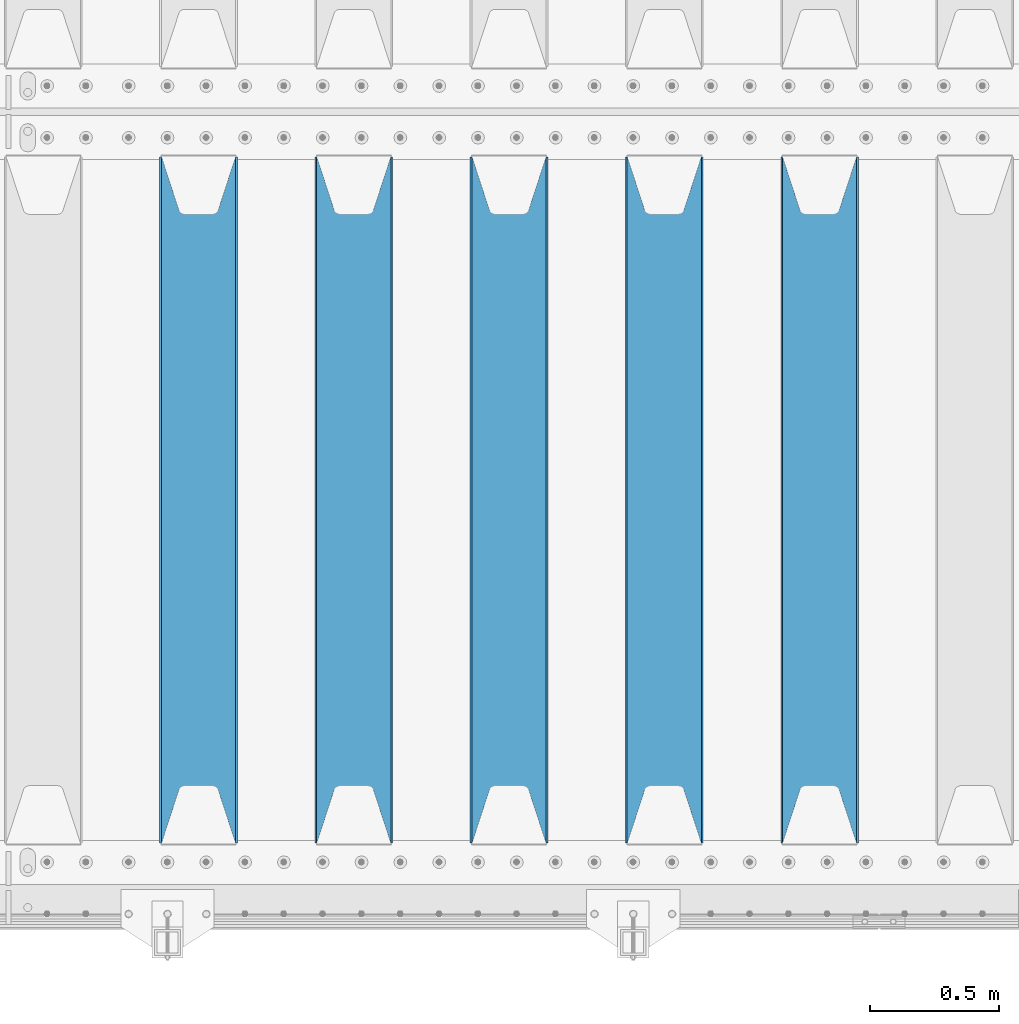
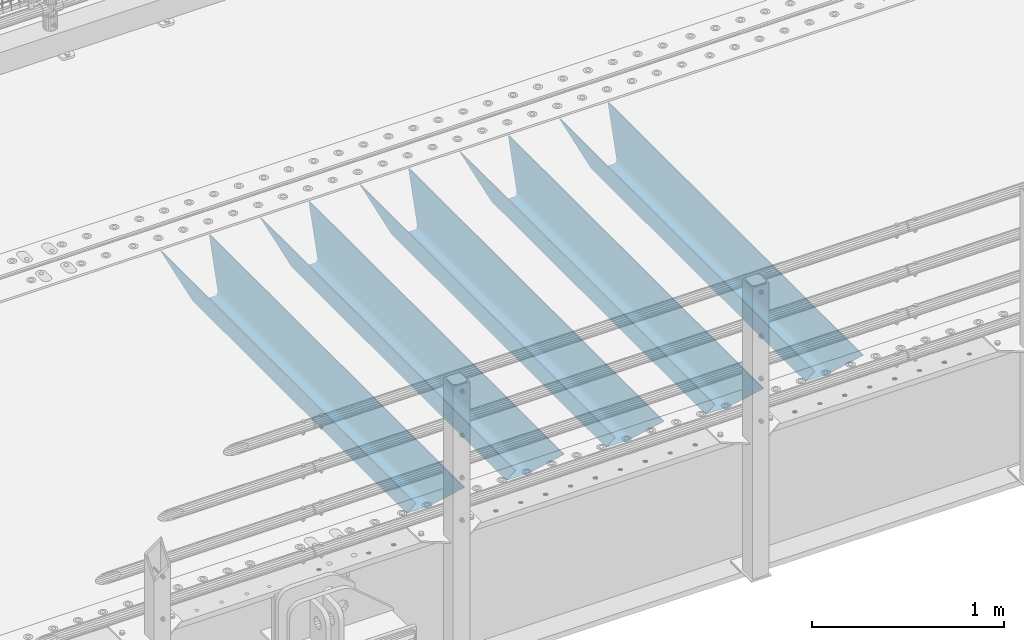
# One storey, part 129 of 242: 5 beams.
"""IFC2X3 building model written with IfcOpenShell, lengths in millimetres."""

from ifc_helpers import new_model, si_unit, frame, origin_with_axes, place, context, subcontext, project, spatial, faceted_brep, material, type_object, element, save


model = new_model("IFC2X3")

# Units and contexts
model_context = context("Model", 3, precision=1e-05, world=origin_with_axes())
body_context = subcontext(model_context, "Body", "Model", "MODEL_VIEW")
ifc_project = project(units=[si_unit("LENGTHUNIT", "METRE", prefix="MILLI"), si_unit("AREAUNIT", "SQUARE_METRE"), si_unit("VOLUMEUNIT", "CUBIC_METRE"), si_unit("MASSUNIT", "GRAM", prefix="KILO"), si_unit("TIMEUNIT", "SECOND"), si_unit("PLANEANGLEUNIT", "RADIAN"), si_unit("SOLIDANGLEUNIT", "STERADIAN"), si_unit("THERMODYNAMICTEMPERATUREUNIT", "DEGREE_CELSIUS"), si_unit("LUMINOUSINTENSITYUNIT", "LUMEN")], contexts=[model_context])

# Site, building, storey
site_placement = place(None, origin_with_axes())
site = spatial("IfcSite", under=ifc_project, at=site_placement, CompositionType="ELEMENT")
building_placement = place(site_placement, origin_with_axes())
building = spatial("IfcBuilding", under=site, at=building_placement, Name="Standard", CompositionType="ELEMENT")
storey_placement = place(building_placement, origin_with_axes())
storey = spatial("IfcBuildingStorey", under=building, at=storey_placement, Name="Undefined", CompositionType="ELEMENT", Elevation=0.0)

# Beams
ifc_material = material(Name="STEEL/S355N")
beam_type = type_object("IfcBeamType", PredefinedType="NOTDEFINED")
beam_1_placement = place(storey_placement, frame((-24980.0, -23825.0, -115.0), z_axis=(0.0, 0.0, 1.0), x_axis=(0.0, 1.0, 0.0)))
element("IfcBeam", 1, at=beam_1_placement, inside=storey, type_object=beam_type, material=ifc_material, context=body_context, shape_type="Brep", body=[
    faceted_brep([(0.0, 150.0, 115.0), (0.0, 143.689999999999, 115.0), (2650.00000000297, 143.689999999999, 115.0), (2650.00000000297, 150.0, 115.0), (2650.00000000297, 142.059565218402, 110.000000003099), (2650.00000000297, 148.369565218403, 110.000000003099), (2441.90079219209, -80.1103600731112, -98.0992078077845), (2437.7588105432, -77.5672621345584, -102.241189456673), (2434.06523489747, -74.4080125315522, -105.934765102404), (2430.91086095089, -70.710272125576, -109.089139048974), (2428.37322971128, -66.5649389910068, -111.626770288588), (2426.51472138055, -62.0739139532889, -113.485278619323), (2425.38102192092, -57.3475956567672, -114.618978078955), (2424.99999999987, -52.5021667386536, -115.0), (2424.99999999987, 52.5021667386536, -115.0), (2425.38102192092, 57.3475956567672, -114.618978078955), (2426.51472138055, 62.0739139532889, -113.485278619323), (2428.37322971128, 66.5649389910068, -111.626770288588), (2430.91086095089, 70.710272125576, -109.089139048974), (2434.06523489747, 74.4080125315522, -105.934765102404), (2437.7588105432, 77.5672621345584, -102.241189456673), (2441.90079219209, 80.1103600731112, -98.0992078077846), (2446.38936140511, 81.9747917625791, -93.6106385947584), (2448.2494850041, 76.2713538057251, -91.7505149957729), (2444.62967112262, 74.76777986261, -95.3703288772456), (2441.28936334126, 72.7168944282894, -98.710636658607), (2438.31067330438, 70.1691124903846, -101.689326695487), (2435.76682334747, 67.1870637758839, -104.233176652398), (2433.72034654133, 63.8440531834895, -106.279653458539), (2432.22154950042, 60.222258798236, -107.778450499454), (2431.30727574265, 56.4107117849089, -108.692724257221), (2430.99999999987, 52.5031078186876, -109.0), (2430.99999999987, -52.5031078186876, -109.0), (2431.30727574265, -56.4107117849089, -108.692724257221), (2432.22154950042, -60.222258798236, -107.778450499454), (2433.72034654133, -63.8440531834895, -106.279653458539), (2435.76682334747, -67.1870637758839, -104.233176652398), (2438.31067330438, -70.1691124903846, -101.689326695487), (2441.28936334126, -72.7168944282894, -98.7106366586071), (2444.62967112262, -74.76777986261, -95.3703288772457), (2448.2494850041, -76.2713538057251, -91.7505149957729), (2650.00000000297, -142.059565218402, 110.000000003099), (2650.00000000297, -148.369565218403, 110.000000003099), (2446.38936140511, -81.9747917625791, -93.6106385947584), (2650.00000000297, -143.689999999999, 115.0), (2650.00000000297, -150.0, 115.0), (0.0, -143.689999999999, 115.0), (0.0, -150.0, 115.0), (0.0, -148.369565218261, 110.000000002669), (203.610638597427, -81.9747917625791, -93.6106385947584), (208.099207810454, -80.1103600731112, -98.0992078077845), (212.241189459342, -77.5672621345584, -102.241189456673), (215.934765105074, -74.4080125315522, -105.934765102404), (219.089139051644, -70.710272125576, -109.089139048974), (221.626770291256, -66.5649389910068, -111.626770288588), (223.485278621993, -62.0739139532889, -113.485278619323), (224.618978081624, -57.3475956567672, -114.618978078955), (225.00000000267, -52.5021667386536, -115.0), (225.00000000267, 52.5021667386536, -115.0), (224.618978081624, 57.3475956567672, -114.618978078955), (223.485278621993, 62.0739139532889, -113.485278619323), (221.626770291256, 66.5649389910068, -111.626770288588), (219.089139051644, 70.710272125576, -109.089139048974), (215.934765105074, 74.4080125315522, -105.934765102404), (212.241189459342, 77.5672621345584, -102.241189456673), (208.099207810454, 80.1103600731112, -98.0992078077846), (203.610638597427, 81.9747917625791, -93.6106385947584), (0.0, 148.369565218261, 110.000000002669), (0.0, 142.05956521826, 110.000000002669), (201.750514998443, 76.2713538057251, -91.7505149957729), (205.370328879915, 74.76777986261, -95.3703288772456), (208.710636661275, 72.7168944282894, -98.710636658607), (211.689326698157, 70.1691124903846, -101.689326695487), (214.233176655067, 67.1870637758839, -104.233176652398), (216.279653461206, 63.8440531834895, -106.279653458539), (217.778450502123, 60.222258798236, -107.778450499454), (218.69272425989, 56.4107117849089, -108.692724257221), (219.00000000267, 52.5031078186876, -109.0), (219.00000000267, -52.5031078186876, -109.0), (218.69272425989, -56.4107117849089, -108.692724257221), (217.778450502123, -60.222258798236, -107.778450499454), (216.279653461206, -63.8440531834895, -106.279653458539), (214.233176655067, -67.1870637758839, -104.233176652398), (211.689326698157, -70.1691124903846, -101.689326695487), (208.710636661275, -72.7168944282894, -98.7106366586071), (205.370328879915, -74.76777986261, -95.3703288772457), (201.750514998443, -76.2713538057251, -91.7505149957729), (0.0, -142.05956521826, 110.000000002669)], [[[0, 1, 2, 3]], [[3, 2, 4, 5]], [[6, 7, 8, 9, 10, 11, 12, 13, 14, 15, 16, 17, 18, 19, 20, 21, 22, 5, 4, 23, 24, 25, 26, 27, 28, 29, 30, 31, 32, 33, 34, 35, 36, 37, 38, 39, 40, 41, 42, 43]], [[44, 45, 42, 41]], [[46, 47, 45, 44]], [[43, 42, 45, 47, 48, 49]], [[6, 43, 49, 50]], [[7, 6, 50, 51]], [[8, 7, 51, 52]], [[9, 8, 52, 53]], [[10, 9, 53, 54]], [[11, 10, 54, 55]], [[12, 11, 55, 56]], [[13, 12, 56, 57]], [[14, 13, 57, 58]], [[15, 14, 58, 59]], [[16, 15, 59, 60]], [[17, 16, 60, 61]], [[18, 17, 61, 62]], [[19, 18, 62, 63]], [[20, 19, 63, 64]], [[21, 20, 64, 65]], [[22, 21, 65, 66]], [[0, 3, 5, 22, 66, 67]], [[1, 0, 67, 68]], [[23, 4, 2, 1, 68, 69]], [[24, 23, 69, 70]], [[25, 24, 70, 71]], [[26, 25, 71, 72]], [[27, 26, 72, 73]], [[28, 27, 73, 74]], [[29, 28, 74, 75]], [[30, 29, 75, 76]], [[31, 30, 76, 77]], [[32, 31, 77, 78]], [[33, 32, 78, 79]], [[34, 33, 79, 80]], [[35, 34, 80, 81]], [[36, 35, 81, 82]], [[37, 36, 82, 83]], [[38, 37, 83, 84]], [[39, 38, 84, 85]], [[40, 39, 85, 86]], [[46, 44, 41, 40, 86, 87]], [[47, 46, 87, 48]], [[86, 85, 84, 83, 82, 81, 80, 79, 78, 77, 76, 75, 74, 73, 72, 71, 70, 69, 68, 67, 66, 65, 64, 63, 62, 61, 60, 59, 58, 57, 56, 55, 54, 53, 52, 51, 50, 49, 48, 87]]]),
])
beam_2_placement = place(storey_placement, frame((-25580.0, -23825.0, -115.0), z_axis=(0.0, 0.0, 1.0), x_axis=(0.0, 1.0, 0.0)))
element("IfcBeam", 2, at=beam_2_placement, inside=storey, type_object=beam_type, material=ifc_material, context=body_context, shape_type="Brep", body=[
    faceted_brep([(0.0, 150.0, 115.0), (0.0, 143.689999999999, 115.0), (2650.00000000297, 143.689999999999, 115.0), (2650.00000000297, 150.0, 115.0), (2650.00000000297, 142.059565218402, 110.000000003099), (2650.00000000297, 148.369565218403, 110.000000003099), (2441.90079219209, -80.1103600731112, -98.0992078077845), (2437.7588105432, -77.5672621345584, -102.241189456673), (2434.06523489747, -74.4080125315522, -105.934765102404), (2430.91086095089, -70.710272125576, -109.089139048974), (2428.37322971128, -66.5649389910068, -111.626770288588), (2426.51472138055, -62.0739139532889, -113.485278619323), (2425.38102192092, -57.3475956567672, -114.618978078955), (2424.99999999987, -52.5021667386536, -115.0), (2424.99999999987, 52.5021667386536, -115.0), (2425.38102192092, 57.3475956567672, -114.618978078955), (2426.51472138055, 62.0739139532889, -113.485278619323), (2428.37322971128, 66.5649389910068, -111.626770288588), (2430.91086095089, 70.710272125576, -109.089139048974), (2434.06523489747, 74.4080125315522, -105.934765102404), (2437.7588105432, 77.5672621345584, -102.241189456673), (2441.90079219209, 80.1103600731112, -98.0992078077846), (2446.38936140511, 81.9747917625791, -93.6106385947584), (2448.2494850041, 76.2713538057251, -91.7505149957729), (2444.62967112262, 74.76777986261, -95.3703288772456), (2441.28936334126, 72.7168944282894, -98.710636658607), (2438.31067330438, 70.1691124903846, -101.689326695487), (2435.76682334747, 67.1870637758839, -104.233176652398), (2433.72034654133, 63.8440531834895, -106.279653458539), (2432.22154950042, 60.222258798236, -107.778450499454), (2431.30727574265, 56.4107117849089, -108.692724257221), (2430.99999999987, 52.5031078186876, -109.0), (2430.99999999987, -52.5031078186876, -109.0), (2431.30727574265, -56.4107117849089, -108.692724257221), (2432.22154950042, -60.222258798236, -107.778450499454), (2433.72034654133, -63.8440531834895, -106.279653458539), (2435.76682334747, -67.1870637758839, -104.233176652398), (2438.31067330438, -70.1691124903846, -101.689326695487), (2441.28936334126, -72.7168944282894, -98.7106366586071), (2444.62967112262, -74.76777986261, -95.3703288772457), (2448.2494850041, -76.2713538057251, -91.7505149957729), (2650.00000000297, -142.059565218402, 110.000000003099), (2650.00000000297, -148.369565218403, 110.000000003099), (2446.38936140511, -81.9747917625791, -93.6106385947584), (2650.00000000297, -143.689999999999, 115.0), (2650.00000000297, -150.0, 115.0), (0.0, -143.689999999999, 115.0), (0.0, -150.0, 115.0), (0.0, -148.369565218261, 110.000000002669), (203.610638597427, -81.9747917625791, -93.6106385947584), (208.099207810454, -80.1103600731112, -98.0992078077845), (212.241189459342, -77.5672621345584, -102.241189456673), (215.934765105074, -74.4080125315522, -105.934765102404), (219.089139051644, -70.710272125576, -109.089139048974), (221.626770291256, -66.5649389910068, -111.626770288588), (223.485278621993, -62.0739139532889, -113.485278619323), (224.618978081624, -57.3475956567672, -114.618978078955), (225.00000000267, -52.5021667386536, -115.0), (225.00000000267, 52.5021667386536, -115.0), (224.618978081624, 57.3475956567672, -114.618978078955), (223.485278621993, 62.0739139532889, -113.485278619323), (221.626770291256, 66.5649389910068, -111.626770288588), (219.089139051644, 70.710272125576, -109.089139048974), (215.934765105074, 74.4080125315522, -105.934765102404), (212.241189459342, 77.5672621345584, -102.241189456673), (208.099207810454, 80.1103600731112, -98.0992078077846), (203.610638597427, 81.9747917625791, -93.6106385947584), (0.0, 148.369565218261, 110.000000002669), (0.0, 142.05956521826, 110.000000002669), (201.750514998443, 76.2713538057251, -91.7505149957729), (205.370328879915, 74.76777986261, -95.3703288772456), (208.710636661275, 72.7168944282894, -98.710636658607), (211.689326698157, 70.1691124903846, -101.689326695487), (214.233176655067, 67.1870637758839, -104.233176652398), (216.279653461206, 63.8440531834895, -106.279653458539), (217.778450502123, 60.222258798236, -107.778450499454), (218.69272425989, 56.4107117849089, -108.692724257221), (219.00000000267, 52.5031078186876, -109.0), (219.00000000267, -52.5031078186876, -109.0), (218.69272425989, -56.4107117849089, -108.692724257221), (217.778450502123, -60.222258798236, -107.778450499454), (216.279653461206, -63.8440531834895, -106.279653458539), (214.233176655067, -67.1870637758839, -104.233176652398), (211.689326698157, -70.1691124903846, -101.689326695487), (208.710636661275, -72.7168944282894, -98.7106366586071), (205.370328879915, -74.76777986261, -95.3703288772457), (201.750514998443, -76.2713538057251, -91.7505149957729), (0.0, -142.05956521826, 110.000000002669)], [[[0, 1, 2, 3]], [[3, 2, 4, 5]], [[6, 7, 8, 9, 10, 11, 12, 13, 14, 15, 16, 17, 18, 19, 20, 21, 22, 5, 4, 23, 24, 25, 26, 27, 28, 29, 30, 31, 32, 33, 34, 35, 36, 37, 38, 39, 40, 41, 42, 43]], [[44, 45, 42, 41]], [[46, 47, 45, 44]], [[43, 42, 45, 47, 48, 49]], [[6, 43, 49, 50]], [[7, 6, 50, 51]], [[8, 7, 51, 52]], [[9, 8, 52, 53]], [[10, 9, 53, 54]], [[11, 10, 54, 55]], [[12, 11, 55, 56]], [[13, 12, 56, 57]], [[14, 13, 57, 58]], [[15, 14, 58, 59]], [[16, 15, 59, 60]], [[17, 16, 60, 61]], [[18, 17, 61, 62]], [[19, 18, 62, 63]], [[20, 19, 63, 64]], [[21, 20, 64, 65]], [[22, 21, 65, 66]], [[0, 3, 5, 22, 66, 67]], [[1, 0, 67, 68]], [[23, 4, 2, 1, 68, 69]], [[24, 23, 69, 70]], [[25, 24, 70, 71]], [[26, 25, 71, 72]], [[27, 26, 72, 73]], [[28, 27, 73, 74]], [[29, 28, 74, 75]], [[30, 29, 75, 76]], [[31, 30, 76, 77]], [[32, 31, 77, 78]], [[33, 32, 78, 79]], [[34, 33, 79, 80]], [[35, 34, 80, 81]], [[36, 35, 81, 82]], [[37, 36, 82, 83]], [[38, 37, 83, 84]], [[39, 38, 84, 85]], [[40, 39, 85, 86]], [[46, 44, 41, 40, 86, 87]], [[47, 46, 87, 48]], [[86, 85, 84, 83, 82, 81, 80, 79, 78, 77, 76, 75, 74, 73, 72, 71, 70, 69, 68, 67, 66, 65, 64, 63, 62, 61, 60, 59, 58, 57, 56, 55, 54, 53, 52, 51, 50, 49, 48, 87]]]),
])
beam_3_placement = place(storey_placement, frame((-26180.0, -23825.0, -115.0), z_axis=(0.0, 0.0, 1.0), x_axis=(0.0, 1.0, 0.0)))
element("IfcBeam", 3, at=beam_3_placement, inside=storey, type_object=beam_type, material=ifc_material, context=body_context, shape_type="Brep", body=[
    faceted_brep([(0.0, 150.0, 115.0), (0.0, 143.689999999999, 115.0), (2650.00000000297, 143.689999999999, 115.0), (2650.00000000297, 150.0, 115.0), (2650.00000000297, 142.059565218402, 110.000000003099), (2650.00000000297, 148.369565218403, 110.000000003099), (2441.90079219209, -80.1103600731112, -98.0992078077845), (2437.7588105432, -77.5672621345584, -102.241189456673), (2434.06523489747, -74.4080125315522, -105.934765102404), (2430.91086095089, -70.710272125576, -109.089139048974), (2428.37322971128, -66.5649389910068, -111.626770288588), (2426.51472138055, -62.0739139532889, -113.485278619323), (2425.38102192092, -57.3475956567672, -114.618978078955), (2424.99999999987, -52.5021667386536, -115.0), (2424.99999999987, 52.5021667386536, -115.0), (2425.38102192092, 57.3475956567672, -114.618978078955), (2426.51472138055, 62.0739139532889, -113.485278619323), (2428.37322971128, 66.5649389910068, -111.626770288588), (2430.91086095089, 70.710272125576, -109.089139048974), (2434.06523489747, 74.4080125315522, -105.934765102404), (2437.7588105432, 77.5672621345584, -102.241189456673), (2441.90079219209, 80.1103600731112, -98.0992078077846), (2446.38936140511, 81.9747917625791, -93.6106385947584), (2448.2494850041, 76.2713538057251, -91.7505149957729), (2444.62967112262, 74.76777986261, -95.3703288772456), (2441.28936334126, 72.7168944282894, -98.710636658607), (2438.31067330438, 70.1691124903846, -101.689326695487), (2435.76682334747, 67.1870637758839, -104.233176652398), (2433.72034654133, 63.8440531834895, -106.279653458539), (2432.22154950042, 60.222258798236, -107.778450499454), (2431.30727574265, 56.4107117849089, -108.692724257221), (2430.99999999987, 52.5031078186876, -109.0), (2430.99999999987, -52.5031078186876, -109.0), (2431.30727574265, -56.4107117849089, -108.692724257221), (2432.22154950042, -60.222258798236, -107.778450499454), (2433.72034654133, -63.8440531834895, -106.279653458539), (2435.76682334747, -67.1870637758839, -104.233176652398), (2438.31067330438, -70.1691124903846, -101.689326695487), (2441.28936334126, -72.7168944282894, -98.7106366586071), (2444.62967112262, -74.76777986261, -95.3703288772457), (2448.2494850041, -76.2713538057251, -91.7505149957729), (2650.00000000297, -142.059565218402, 110.000000003099), (2650.00000000297, -148.369565218403, 110.000000003099), (2446.38936140511, -81.9747917625791, -93.6106385947584), (2650.00000000297, -143.689999999999, 115.0), (2650.00000000297, -150.0, 115.0), (0.0, -143.689999999999, 115.0), (0.0, -150.0, 115.0), (0.0, -148.369565218261, 110.000000002669), (203.610638597427, -81.9747917625791, -93.6106385947584), (208.099207810454, -80.1103600731112, -98.0992078077845), (212.241189459342, -77.5672621345584, -102.241189456673), (215.934765105074, -74.4080125315522, -105.934765102404), (219.089139051644, -70.710272125576, -109.089139048974), (221.626770291256, -66.5649389910068, -111.626770288588), (223.485278621993, -62.0739139532889, -113.485278619323), (224.618978081624, -57.3475956567672, -114.618978078955), (225.00000000267, -52.5021667386536, -115.0), (225.00000000267, 52.5021667386536, -115.0), (224.618978081624, 57.3475956567672, -114.618978078955), (223.485278621993, 62.0739139532889, -113.485278619323), (221.626770291256, 66.5649389910068, -111.626770288588), (219.089139051644, 70.710272125576, -109.089139048974), (215.934765105074, 74.4080125315522, -105.934765102404), (212.241189459342, 77.5672621345584, -102.241189456673), (208.099207810454, 80.1103600731112, -98.0992078077846), (203.610638597427, 81.9747917625791, -93.6106385947584), (0.0, 148.369565218261, 110.000000002669), (0.0, 142.05956521826, 110.000000002669), (201.750514998443, 76.2713538057251, -91.7505149957729), (205.370328879915, 74.76777986261, -95.3703288772456), (208.710636661275, 72.7168944282894, -98.710636658607), (211.689326698157, 70.1691124903846, -101.689326695487), (214.233176655067, 67.1870637758839, -104.233176652398), (216.279653461206, 63.8440531834895, -106.279653458539), (217.778450502123, 60.222258798236, -107.778450499454), (218.69272425989, 56.4107117849089, -108.692724257221), (219.00000000267, 52.5031078186876, -109.0), (219.00000000267, -52.5031078186876, -109.0), (218.69272425989, -56.4107117849089, -108.692724257221), (217.778450502123, -60.222258798236, -107.778450499454), (216.279653461206, -63.8440531834895, -106.279653458539), (214.233176655067, -67.1870637758839, -104.233176652398), (211.689326698157, -70.1691124903846, -101.689326695487), (208.710636661275, -72.7168944282894, -98.7106366586071), (205.370328879915, -74.76777986261, -95.3703288772457), (201.750514998443, -76.2713538057251, -91.7505149957729), (0.0, -142.05956521826, 110.000000002669)], [[[0, 1, 2, 3]], [[3, 2, 4, 5]], [[6, 7, 8, 9, 10, 11, 12, 13, 14, 15, 16, 17, 18, 19, 20, 21, 22, 5, 4, 23, 24, 25, 26, 27, 28, 29, 30, 31, 32, 33, 34, 35, 36, 37, 38, 39, 40, 41, 42, 43]], [[44, 45, 42, 41]], [[46, 47, 45, 44]], [[43, 42, 45, 47, 48, 49]], [[6, 43, 49, 50]], [[7, 6, 50, 51]], [[8, 7, 51, 52]], [[9, 8, 52, 53]], [[10, 9, 53, 54]], [[11, 10, 54, 55]], [[12, 11, 55, 56]], [[13, 12, 56, 57]], [[14, 13, 57, 58]], [[15, 14, 58, 59]], [[16, 15, 59, 60]], [[17, 16, 60, 61]], [[18, 17, 61, 62]], [[19, 18, 62, 63]], [[20, 19, 63, 64]], [[21, 20, 64, 65]], [[22, 21, 65, 66]], [[0, 3, 5, 22, 66, 67]], [[1, 0, 67, 68]], [[23, 4, 2, 1, 68, 69]], [[24, 23, 69, 70]], [[25, 24, 70, 71]], [[26, 25, 71, 72]], [[27, 26, 72, 73]], [[28, 27, 73, 74]], [[29, 28, 74, 75]], [[30, 29, 75, 76]], [[31, 30, 76, 77]], [[32, 31, 77, 78]], [[33, 32, 78, 79]], [[34, 33, 79, 80]], [[35, 34, 80, 81]], [[36, 35, 81, 82]], [[37, 36, 82, 83]], [[38, 37, 83, 84]], [[39, 38, 84, 85]], [[40, 39, 85, 86]], [[46, 44, 41, 40, 86, 87]], [[47, 46, 87, 48]], [[86, 85, 84, 83, 82, 81, 80, 79, 78, 77, 76, 75, 74, 73, 72, 71, 70, 69, 68, 67, 66, 65, 64, 63, 62, 61, 60, 59, 58, 57, 56, 55, 54, 53, 52, 51, 50, 49, 48, 87]]]),
])
beam_4_placement = place(storey_placement, frame((-26780.0, -23825.0, -115.0), z_axis=(0.0, 0.0, 1.0), x_axis=(0.0, 1.0, 0.0)))
element("IfcBeam", 4, at=beam_4_placement, inside=storey, type_object=beam_type, material=ifc_material, context=body_context, shape_type="Brep", body=[
    faceted_brep([(0.0, 150.0, 115.0), (0.0, 143.689999999999, 115.0), (2650.00000000297, 143.689999999999, 115.0), (2650.00000000297, 150.0, 115.0), (2650.00000000297, 142.059565218402, 110.000000003099), (2650.00000000297, 148.369565218403, 110.000000003099), (2441.90079219209, -80.1103600731112, -98.0992078077845), (2437.7588105432, -77.5672621345584, -102.241189456673), (2434.06523489747, -74.4080125315522, -105.934765102404), (2430.91086095089, -70.710272125576, -109.089139048974), (2428.37322971128, -66.5649389910068, -111.626770288588), (2426.51472138055, -62.0739139532889, -113.485278619323), (2425.38102192092, -57.3475956567672, -114.618978078955), (2424.99999999987, -52.5021667386536, -115.0), (2424.99999999987, 52.5021667386536, -115.0), (2425.38102192092, 57.3475956567672, -114.618978078955), (2426.51472138055, 62.0739139532889, -113.485278619323), (2428.37322971128, 66.5649389910068, -111.626770288588), (2430.91086095089, 70.710272125576, -109.089139048974), (2434.06523489747, 74.4080125315522, -105.934765102404), (2437.7588105432, 77.5672621345584, -102.241189456673), (2441.90079219209, 80.1103600731112, -98.0992078077846), (2446.38936140511, 81.9747917625791, -93.6106385947584), (2448.2494850041, 76.2713538057251, -91.7505149957729), (2444.62967112262, 74.76777986261, -95.3703288772456), (2441.28936334126, 72.7168944282894, -98.710636658607), (2438.31067330438, 70.1691124903846, -101.689326695487), (2435.76682334747, 67.1870637758839, -104.233176652398), (2433.72034654133, 63.8440531834895, -106.279653458539), (2432.22154950042, 60.222258798236, -107.778450499454), (2431.30727574265, 56.4107117849089, -108.692724257221), (2430.99999999987, 52.5031078186876, -109.0), (2430.99999999987, -52.5031078186876, -109.0), (2431.30727574265, -56.4107117849089, -108.692724257221), (2432.22154950042, -60.222258798236, -107.778450499454), (2433.72034654133, -63.8440531834895, -106.279653458539), (2435.76682334747, -67.1870637758839, -104.233176652398), (2438.31067330438, -70.1691124903846, -101.689326695487), (2441.28936334126, -72.7168944282894, -98.7106366586071), (2444.62967112262, -74.76777986261, -95.3703288772457), (2448.2494850041, -76.2713538057251, -91.7505149957729), (2650.00000000297, -142.059565218402, 110.000000003099), (2650.00000000297, -148.369565218403, 110.000000003099), (2446.38936140511, -81.9747917625791, -93.6106385947584), (2650.00000000297, -143.689999999999, 115.0), (2650.00000000297, -150.0, 115.0), (0.0, -143.689999999999, 115.0), (0.0, -150.0, 115.0), (0.0, -148.369565218261, 110.000000002669), (203.610638597427, -81.9747917625791, -93.6106385947584), (208.099207810454, -80.1103600731112, -98.0992078077845), (212.241189459342, -77.5672621345584, -102.241189456673), (215.934765105074, -74.4080125315522, -105.934765102404), (219.089139051644, -70.710272125576, -109.089139048974), (221.626770291256, -66.5649389910068, -111.626770288588), (223.485278621993, -62.0739139532889, -113.485278619323), (224.618978081624, -57.3475956567672, -114.618978078955), (225.00000000267, -52.5021667386536, -115.0), (225.00000000267, 52.5021667386536, -115.0), (224.618978081624, 57.3475956567672, -114.618978078955), (223.485278621993, 62.0739139532889, -113.485278619323), (221.626770291256, 66.5649389910068, -111.626770288588), (219.089139051644, 70.710272125576, -109.089139048974), (215.934765105074, 74.4080125315522, -105.934765102404), (212.241189459342, 77.5672621345584, -102.241189456673), (208.099207810454, 80.1103600731112, -98.0992078077846), (203.610638597427, 81.9747917625791, -93.6106385947584), (0.0, 148.369565218261, 110.000000002669), (0.0, 142.05956521826, 110.000000002669), (201.750514998443, 76.2713538057251, -91.7505149957729), (205.370328879915, 74.76777986261, -95.3703288772456), (208.710636661275, 72.7168944282894, -98.710636658607), (211.689326698157, 70.1691124903846, -101.689326695487), (214.233176655067, 67.1870637758839, -104.233176652398), (216.279653461206, 63.8440531834895, -106.279653458539), (217.778450502123, 60.222258798236, -107.778450499454), (218.69272425989, 56.4107117849089, -108.692724257221), (219.00000000267, 52.5031078186876, -109.0), (219.00000000267, -52.5031078186876, -109.0), (218.69272425989, -56.4107117849089, -108.692724257221), (217.778450502123, -60.222258798236, -107.778450499454), (216.279653461206, -63.8440531834895, -106.279653458539), (214.233176655067, -67.1870637758839, -104.233176652398), (211.689326698157, -70.1691124903846, -101.689326695487), (208.710636661275, -72.7168944282894, -98.7106366586071), (205.370328879915, -74.76777986261, -95.3703288772457), (201.750514998443, -76.2713538057251, -91.7505149957729), (0.0, -142.05956521826, 110.000000002669)], [[[0, 1, 2, 3]], [[3, 2, 4, 5]], [[6, 7, 8, 9, 10, 11, 12, 13, 14, 15, 16, 17, 18, 19, 20, 21, 22, 5, 4, 23, 24, 25, 26, 27, 28, 29, 30, 31, 32, 33, 34, 35, 36, 37, 38, 39, 40, 41, 42, 43]], [[44, 45, 42, 41]], [[46, 47, 45, 44]], [[43, 42, 45, 47, 48, 49]], [[6, 43, 49, 50]], [[7, 6, 50, 51]], [[8, 7, 51, 52]], [[9, 8, 52, 53]], [[10, 9, 53, 54]], [[11, 10, 54, 55]], [[12, 11, 55, 56]], [[13, 12, 56, 57]], [[14, 13, 57, 58]], [[15, 14, 58, 59]], [[16, 15, 59, 60]], [[17, 16, 60, 61]], [[18, 17, 61, 62]], [[19, 18, 62, 63]], [[20, 19, 63, 64]], [[21, 20, 64, 65]], [[22, 21, 65, 66]], [[0, 3, 5, 22, 66, 67]], [[1, 0, 67, 68]], [[23, 4, 2, 1, 68, 69]], [[24, 23, 69, 70]], [[25, 24, 70, 71]], [[26, 25, 71, 72]], [[27, 26, 72, 73]], [[28, 27, 73, 74]], [[29, 28, 74, 75]], [[30, 29, 75, 76]], [[31, 30, 76, 77]], [[32, 31, 77, 78]], [[33, 32, 78, 79]], [[34, 33, 79, 80]], [[35, 34, 80, 81]], [[36, 35, 81, 82]], [[37, 36, 82, 83]], [[38, 37, 83, 84]], [[39, 38, 84, 85]], [[40, 39, 85, 86]], [[46, 44, 41, 40, 86, 87]], [[47, 46, 87, 48]], [[86, 85, 84, 83, 82, 81, 80, 79, 78, 77, 76, 75, 74, 73, 72, 71, 70, 69, 68, 67, 66, 65, 64, 63, 62, 61, 60, 59, 58, 57, 56, 55, 54, 53, 52, 51, 50, 49, 48, 87]]]),
])
beam_5_placement = place(storey_placement, frame((-27380.0, -23825.0, -115.0), z_axis=(0.0, 0.0, 1.0), x_axis=(0.0, 1.0, 0.0)))
element("IfcBeam", 5, at=beam_5_placement, inside=storey, type_object=beam_type, material=ifc_material, context=body_context, shape_type="Brep", body=[
    faceted_brep([(0.0, 150.0, 115.0), (0.0, 143.689999999999, 115.0), (2650.00000000297, 143.689999999999, 115.0), (2650.00000000297, 150.0, 115.0), (2650.00000000297, 142.059565218402, 110.000000003099), (2650.00000000297, 148.369565218403, 110.000000003099), (2441.90079219209, -80.1103600731112, -98.0992078077845), (2437.7588105432, -77.5672621345584, -102.241189456673), (2434.06523489747, -74.4080125315522, -105.934765102404), (2430.91086095089, -70.710272125576, -109.089139048974), (2428.37322971128, -66.5649389910068, -111.626770288588), (2426.51472138055, -62.0739139532889, -113.485278619323), (2425.38102192092, -57.3475956567672, -114.618978078955), (2424.99999999987, -52.5021667386536, -115.0), (2424.99999999987, 52.5021667386536, -115.0), (2425.38102192092, 57.3475956567672, -114.618978078955), (2426.51472138055, 62.0739139532889, -113.485278619323), (2428.37322971128, 66.5649389910068, -111.626770288588), (2430.91086095089, 70.710272125576, -109.089139048974), (2434.06523489747, 74.4080125315522, -105.934765102404), (2437.7588105432, 77.5672621345584, -102.241189456673), (2441.90079219209, 80.1103600731112, -98.0992078077846), (2446.38936140511, 81.9747917625791, -93.6106385947584), (2448.2494850041, 76.2713538057251, -91.7505149957729), (2444.62967112262, 74.76777986261, -95.3703288772456), (2441.28936334126, 72.7168944282894, -98.710636658607), (2438.31067330438, 70.1691124903846, -101.689326695487), (2435.76682334747, 67.1870637758839, -104.233176652398), (2433.72034654133, 63.8440531834895, -106.279653458539), (2432.22154950042, 60.222258798236, -107.778450499454), (2431.30727574265, 56.4107117849089, -108.692724257221), (2430.99999999987, 52.5031078186876, -109.0), (2430.99999999987, -52.5031078186876, -109.0), (2431.30727574265, -56.4107117849089, -108.692724257221), (2432.22154950042, -60.222258798236, -107.778450499454), (2433.72034654133, -63.8440531834895, -106.279653458539), (2435.76682334747, -67.1870637758839, -104.233176652398), (2438.31067330438, -70.1691124903846, -101.689326695487), (2441.28936334126, -72.7168944282894, -98.7106366586071), (2444.62967112262, -74.76777986261, -95.3703288772457), (2448.2494850041, -76.2713538057251, -91.7505149957729), (2650.00000000297, -142.059565218402, 110.000000003099), (2650.00000000297, -148.369565218403, 110.000000003099), (2446.38936140511, -81.9747917625791, -93.6106385947584), (2650.00000000297, -143.689999999999, 115.0), (2650.00000000297, -150.0, 115.0), (0.0, -143.689999999999, 115.0), (0.0, -150.0, 115.0), (0.0, -148.369565218261, 110.000000002669), (203.610638597427, -81.9747917625791, -93.6106385947584), (208.099207810454, -80.1103600731112, -98.0992078077845), (212.241189459342, -77.5672621345584, -102.241189456673), (215.934765105074, -74.4080125315522, -105.934765102404), (219.089139051644, -70.710272125576, -109.089139048974), (221.626770291256, -66.5649389910068, -111.626770288588), (223.485278621993, -62.0739139532889, -113.485278619323), (224.618978081624, -57.3475956567672, -114.618978078955), (225.00000000267, -52.5021667386536, -115.0), (225.00000000267, 52.5021667386536, -115.0), (224.618978081624, 57.3475956567672, -114.618978078955), (223.485278621993, 62.0739139532889, -113.485278619323), (221.626770291256, 66.5649389910068, -111.626770288588), (219.089139051644, 70.710272125576, -109.089139048974), (215.934765105074, 74.4080125315522, -105.934765102404), (212.241189459342, 77.5672621345584, -102.241189456673), (208.099207810454, 80.1103600731112, -98.0992078077846), (203.610638597427, 81.9747917625791, -93.6106385947584), (0.0, 148.369565218261, 110.000000002669), (0.0, 142.05956521826, 110.000000002669), (201.750514998443, 76.2713538057251, -91.7505149957729), (205.370328879915, 74.76777986261, -95.3703288772456), (208.710636661275, 72.7168944282894, -98.710636658607), (211.689326698157, 70.1691124903846, -101.689326695487), (214.233176655067, 67.1870637758839, -104.233176652398), (216.279653461206, 63.8440531834895, -106.279653458539), (217.778450502123, 60.222258798236, -107.778450499454), (218.69272425989, 56.4107117849089, -108.692724257221), (219.00000000267, 52.5031078186876, -109.0), (219.00000000267, -52.5031078186876, -109.0), (218.69272425989, -56.4107117849089, -108.692724257221), (217.778450502123, -60.222258798236, -107.778450499454), (216.279653461206, -63.8440531834895, -106.279653458539), (214.233176655067, -67.1870637758839, -104.233176652398), (211.689326698157, -70.1691124903846, -101.689326695487), (208.710636661275, -72.7168944282894, -98.7106366586071), (205.370328879915, -74.76777986261, -95.3703288772457), (201.750514998443, -76.2713538057251, -91.7505149957729), (0.0, -142.05956521826, 110.000000002669)], [[[0, 1, 2, 3]], [[3, 2, 4, 5]], [[6, 7, 8, 9, 10, 11, 12, 13, 14, 15, 16, 17, 18, 19, 20, 21, 22, 5, 4, 23, 24, 25, 26, 27, 28, 29, 30, 31, 32, 33, 34, 35, 36, 37, 38, 39, 40, 41, 42, 43]], [[44, 45, 42, 41]], [[46, 47, 45, 44]], [[43, 42, 45, 47, 48, 49]], [[6, 43, 49, 50]], [[7, 6, 50, 51]], [[8, 7, 51, 52]], [[9, 8, 52, 53]], [[10, 9, 53, 54]], [[11, 10, 54, 55]], [[12, 11, 55, 56]], [[13, 12, 56, 57]], [[14, 13, 57, 58]], [[15, 14, 58, 59]], [[16, 15, 59, 60]], [[17, 16, 60, 61]], [[18, 17, 61, 62]], [[19, 18, 62, 63]], [[20, 19, 63, 64]], [[21, 20, 64, 65]], [[22, 21, 65, 66]], [[0, 3, 5, 22, 66, 67]], [[1, 0, 67, 68]], [[23, 4, 2, 1, 68, 69]], [[24, 23, 69, 70]], [[25, 24, 70, 71]], [[26, 25, 71, 72]], [[27, 26, 72, 73]], [[28, 27, 73, 74]], [[29, 28, 74, 75]], [[30, 29, 75, 76]], [[31, 30, 76, 77]], [[32, 31, 77, 78]], [[33, 32, 78, 79]], [[34, 33, 79, 80]], [[35, 34, 80, 81]], [[36, 35, 81, 82]], [[37, 36, 82, 83]], [[38, 37, 83, 84]], [[39, 38, 84, 85]], [[40, 39, 85, 86]], [[46, 44, 41, 40, 86, 87]], [[47, 46, 87, 48]], [[86, 85, 84, 83, 82, 81, 80, 79, 78, 77, 76, 75, 74, 73, 72, 71, 70, 69, 68, 67, 66, 65, 64, 63, 62, 61, 60, 59, 58, 57, 56, 55, 54, 53, 52, 51, 50, 49, 48, 87]]]),
])

save(model, "model.ifc")
